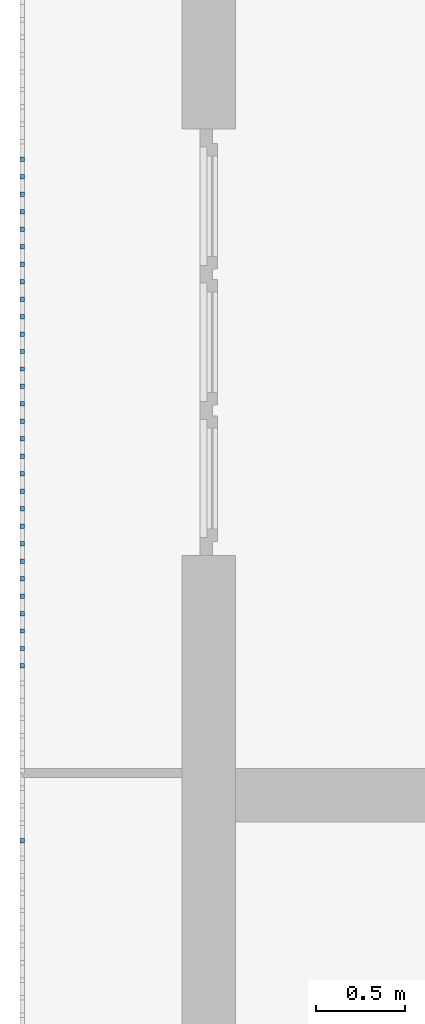
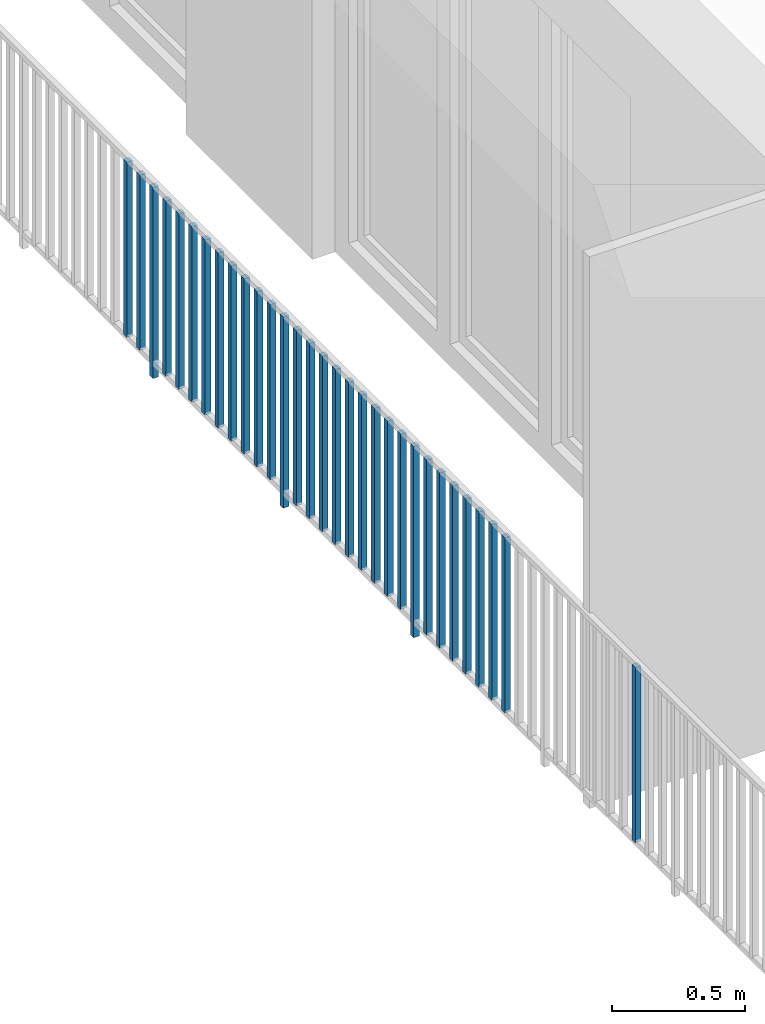
# One storey, part 38 of 54: 31 building element parts, 1 element without a shape of its own.
"""IFC4 building model written with IfcOpenShell, lengths in metres."""

from ifc_helpers import new_model, entity, si_unit, converted_unit, derived_unit, direction, frame, origin_with_axes, place, context, subcontext, project, spatial, polygons, material, type_object, element, aggregate, save


model = new_model("IFC4")

# Units and contexts
model_context = context("Model", 3, precision=1e-05, world=origin_with_axes(), true_north=direction((0.0, 1.0)))
body_context = subcontext(model_context, "Body", "Model", "MODEL_VIEW")
ifc_project = project(units=[si_unit("LENGTHUNIT", "METRE"), si_unit("AREAUNIT", "SQUARE_METRE"), si_unit("VOLUMEUNIT", "CUBIC_METRE"), converted_unit("PLANEANGLEUNIT", "DEGREE", entity("IfcPlaneAngleMeasure", 0.0174532925199), si_unit("PLANEANGLEUNIT", "RADIAN"), dimensions=[0, 0, 0, 0, 0, 0, 0]), converted_unit("TIMEUNIT", "Year", entity("IfcTimeMeasure", 31556926.0), si_unit("TIMEUNIT", "SECOND"), dimensions=[0, 0, 1, 0, 0, 0, 0]), si_unit("MASSUNIT", "GRAM", prefix="KILO"), si_unit("THERMODYNAMICTEMPERATUREUNIT", "DEGREE_CELSIUS"), si_unit("LUMINOUSINTENSITYUNIT", "LUMEN"), si_unit("ENERGYUNIT", "JOULE", prefix="MEGA"), derived_unit("THERMALCONDUCTANCEUNIT", [(si_unit("POWERUNIT", "WATT"), 1), (si_unit("LENGTHUNIT", "METRE"), -1), (si_unit("THERMODYNAMICTEMPERATUREUNIT", "KELVIN"), -1)]), derived_unit("SPECIFICHEATCAPACITYUNIT", [(si_unit("ENERGYUNIT", "JOULE"), 1), (si_unit("MASSUNIT", "GRAM", prefix="KILO"), -1), (si_unit("THERMODYNAMICTEMPERATUREUNIT", "KELVIN"), -1)]), derived_unit("MASSDENSITYUNIT", [(si_unit("MASSUNIT", "GRAM", prefix="KILO"), 1), (si_unit("VOLUMEUNIT", "CUBIC_METRE"), -1)])], contexts=[model_context])

# Site, building, storey, space
site_placement = place(None, origin_with_axes())
site = spatial("IfcSite", under=ifc_project, at=site_placement, CompositionType="ELEMENT")
building_placement = place(site_placement, origin_with_axes())
building = spatial("IfcBuilding", under=site, at=building_placement, CompositionType="ELEMENT")
storey_placement = place(building_placement, frame((0.0, 0.0, 6.29), z_axis=(0.0, 0.0, 1.0), x_axis=(1.0, 0.0, 0.0)))
storey = spatial("IfcBuildingStorey", under=building, at=storey_placement, Name="2. Geschoss", CompositionType="ELEMENT", Elevation=6.29)
space_placement = place(storey_placement, frame((10.2378006196, 9.82118769833, 0.0), z_axis=(0.0, 0.0, 1.0), x_axis=(-1.0, 0.0, 0.0)))
space = spatial("IfcSpace", under=storey, at=space_placement, CompositionType="ELEMENT", PredefinedType="EXTERNAL")

# Railing, building element parts
railing_type = type_object("IfcRailingType", PredefinedType="NOTDEFINED")
railing_placement = place(space_placement, frame((0.0, -7.06315681498e-08, 0.0), z_axis=(0.0, 0.0, 1.0), x_axis=(-1.0, 0.0, 0.0)))
railing = element("IfcRailing", 1, at=railing_placement, inside=space, type_object=railing_type, PredefinedType="NOTDEFINED")
ifc_material = material()
building_element_part_1_placement = place(railing_placement, origin_with_axes())
building_element_part_1 = element("IfcBuildingElementPart", 2, at=building_element_part_1_placement, material=ifc_material, PredefinedType="NOTDEFINED", context=body_context, shape_type="Tessellation", body=[
    polygons([(-22.8925, -4.7325, 0.07), (-22.8675, -4.7325, 0.07), (-22.8675, -4.7325, 0.8775), (-22.8925, -4.7325, 0.8775), (-22.8925, -4.7075, 0.07), (-22.8675, -4.7075, 0.07), (-22.8675, -4.7075, 0.8775), (-22.8925, -4.7075, 0.8775)], [[[1, 2, 3, 4]], [[1, 5, 6, 2]], [[2, 6, 7, 3]], [[4, 3, 7, 8]], [[5, 1, 4, 8]], [[6, 5, 8, 7]]], closed=True),
])
building_element_part_2_placement = place(railing_placement, origin_with_axes())
building_element_part_2 = element("IfcBuildingElementPart", 3, at=building_element_part_2_placement, material=ifc_material, PredefinedType="NOTDEFINED", context=body_context, shape_type="Tessellation", body=[
    polygons([(-22.8925, -4.83083333333, 0.07), (-22.8675, -4.83083333333, 0.07), (-22.8675, -4.83083333333, 0.8775), (-22.8925, -4.83083333333, 0.8775), (-22.8925, -4.80583333333, 0.07), (-22.8675, -4.80583333333, 0.07), (-22.8675, -4.80583333333, 0.8775), (-22.8925, -4.80583333333, 0.8775)], [[[1, 2, 3, 4]], [[1, 5, 6, 2]], [[2, 6, 7, 3]], [[4, 3, 7, 8]], [[5, 1, 4, 8]], [[6, 5, 8, 7]]], closed=True),
])
building_element_part_3_placement = place(railing_placement, origin_with_axes())
building_element_part_3 = element("IfcBuildingElementPart", 4, at=building_element_part_3_placement, material=ifc_material, PredefinedType="NOTDEFINED", context=body_context, shape_type="Tessellation", body=[
    polygons([(-22.8925, -4.92916666667, 0.0), (-22.8675, -4.92916666667, 0.0), (-22.8675, -4.92916666667, 0.88), (-22.8925, -4.92916666667, 0.88), (-22.8925, -4.90416666667, 0.0), (-22.8675, -4.90416666667, 0.0), (-22.8675, -4.90416666667, 0.88), (-22.8925, -4.90416666667, 0.88)], [[[1, 2, 3, 4]], [[1, 5, 6, 2]], [[2, 6, 7, 3]], [[4, 3, 7, 8]], [[5, 1, 4, 8]], [[6, 5, 8, 7]]], closed=True),
])
building_element_part_4_placement = place(railing_placement, origin_with_axes())
building_element_part_4 = element("IfcBuildingElementPart", 5, at=building_element_part_4_placement, material=ifc_material, PredefinedType="NOTDEFINED", context=body_context, shape_type="Tessellation", body=[
    polygons([(-22.8925, -5.0275, 0.07), (-22.8675, -5.0275, 0.07), (-22.8675, -5.0275, 0.8775), (-22.8925, -5.0275, 0.8775), (-22.8925, -5.0025, 0.07), (-22.8675, -5.0025, 0.07), (-22.8675, -5.0025, 0.8775), (-22.8925, -5.0025, 0.8775)], [[[1, 2, 3, 4]], [[1, 5, 6, 2]], [[2, 6, 7, 3]], [[4, 3, 7, 8]], [[5, 1, 4, 8]], [[6, 5, 8, 7]]], closed=True),
])
building_element_part_5_placement = place(railing_placement, origin_with_axes())
building_element_part_5 = element("IfcBuildingElementPart", 6, at=building_element_part_5_placement, material=ifc_material, PredefinedType="NOTDEFINED", context=body_context, shape_type="Tessellation", body=[
    polygons([(-22.8925, -5.12583333333, 0.07), (-22.8675, -5.12583333333, 0.07), (-22.8675, -5.12583333333, 0.8775), (-22.8925, -5.12583333333, 0.8775), (-22.8925, -5.10083333333, 0.07), (-22.8675, -5.10083333333, 0.07), (-22.8675, -5.10083333333, 0.8775), (-22.8925, -5.10083333333, 0.8775)], [[[1, 2, 3, 4]], [[1, 5, 6, 2]], [[2, 6, 7, 3]], [[4, 3, 7, 8]], [[5, 1, 4, 8]], [[6, 5, 8, 7]]], closed=True),
])
building_element_part_6_placement = place(railing_placement, origin_with_axes())
building_element_part_6 = element("IfcBuildingElementPart", 7, at=building_element_part_6_placement, material=ifc_material, PredefinedType="NOTDEFINED", context=body_context, shape_type="Tessellation", body=[
    polygons([(-22.8925, -5.22416666667, 0.07), (-22.8675, -5.22416666667, 0.07), (-22.8675, -5.22416666667, 0.8775), (-22.8925, -5.22416666667, 0.8775), (-22.8925, -5.19916666667, 0.07), (-22.8675, -5.19916666667, 0.07), (-22.8675, -5.19916666667, 0.8775), (-22.8925, -5.19916666667, 0.8775)], [[[1, 2, 3, 4]], [[1, 5, 6, 2]], [[2, 6, 7, 3]], [[4, 3, 7, 8]], [[5, 1, 4, 8]], [[6, 5, 8, 7]]], closed=True),
])
building_element_part_7_placement = place(railing_placement, origin_with_axes())
building_element_part_7 = element("IfcBuildingElementPart", 8, at=building_element_part_7_placement, material=ifc_material, PredefinedType="NOTDEFINED", context=body_context, shape_type="Tessellation", body=[
    polygons([(-22.8925, -5.3225, 0.07), (-22.8675, -5.3225, 0.07), (-22.8675, -5.3225, 0.8775), (-22.8925, -5.3225, 0.8775), (-22.8925, -5.2975, 0.07), (-22.8675, -5.2975, 0.07), (-22.8675, -5.2975, 0.8775), (-22.8925, -5.2975, 0.8775)], [[[1, 2, 3, 4]], [[1, 5, 6, 2]], [[2, 6, 7, 3]], [[4, 3, 7, 8]], [[5, 1, 4, 8]], [[6, 5, 8, 7]]], closed=True),
])
building_element_part_8_placement = place(railing_placement, origin_with_axes())
building_element_part_8 = element("IfcBuildingElementPart", 9, at=building_element_part_8_placement, material=ifc_material, PredefinedType="NOTDEFINED", context=body_context, shape_type="Tessellation", body=[
    polygons([(-22.8925, -5.42083333333, 0.07), (-22.8675, -5.42083333333, 0.07), (-22.8675, -5.42083333333, 0.8775), (-22.8925, -5.42083333333, 0.8775), (-22.8925, -5.39583333333, 0.07), (-22.8675, -5.39583333333, 0.07), (-22.8675, -5.39583333333, 0.8775), (-22.8925, -5.39583333333, 0.8775)], [[[1, 2, 3, 4]], [[1, 5, 6, 2]], [[2, 6, 7, 3]], [[4, 3, 7, 8]], [[5, 1, 4, 8]], [[6, 5, 8, 7]]], closed=True),
])
building_element_part_9_placement = place(railing_placement, origin_with_axes())
building_element_part_9 = element("IfcBuildingElementPart", 10, at=building_element_part_9_placement, material=ifc_material, PredefinedType="NOTDEFINED", context=body_context, shape_type="Tessellation", body=[
    polygons([(-22.8925, -5.51916666667, 0.07), (-22.8675, -5.51916666667, 0.07), (-22.8675, -5.51916666667, 0.8775), (-22.8925, -5.51916666667, 0.8775), (-22.8925, -5.49416666667, 0.07), (-22.8675, -5.49416666667, 0.07), (-22.8675, -5.49416666667, 0.8775), (-22.8925, -5.49416666667, 0.8775)], [[[1, 2, 3, 4]], [[1, 5, 6, 2]], [[2, 6, 7, 3]], [[4, 3, 7, 8]], [[5, 1, 4, 8]], [[6, 5, 8, 7]]], closed=True),
])
building_element_part_10_placement = place(railing_placement, origin_with_axes())
building_element_part_10 = element("IfcBuildingElementPart", 11, at=building_element_part_10_placement, material=ifc_material, PredefinedType="NOTDEFINED", context=body_context, shape_type="Tessellation", body=[
    polygons([(-22.8925, -5.6175, 0.07), (-22.8675, -5.6175, 0.07), (-22.8675, -5.6175, 0.8775), (-22.8925, -5.6175, 0.8775), (-22.8925, -5.5925, 0.07), (-22.8675, -5.5925, 0.07), (-22.8675, -5.5925, 0.8775), (-22.8925, -5.5925, 0.8775)], [[[1, 2, 3, 4]], [[1, 5, 6, 2]], [[2, 6, 7, 3]], [[4, 3, 7, 8]], [[5, 1, 4, 8]], [[6, 5, 8, 7]]], closed=True),
])
building_element_part_11_placement = place(railing_placement, origin_with_axes())
building_element_part_11 = element("IfcBuildingElementPart", 12, at=building_element_part_11_placement, material=ifc_material, PredefinedType="NOTDEFINED", context=body_context, shape_type="Tessellation", body=[
    polygons([(-22.8925, -5.71583333333, 0.07), (-22.8675, -5.71583333333, 0.07), (-22.8675, -5.71583333333, 0.8775), (-22.8925, -5.71583333333, 0.8775), (-22.8925, -5.69083333333, 0.07), (-22.8675, -5.69083333333, 0.07), (-22.8675, -5.69083333333, 0.8775), (-22.8925, -5.69083333333, 0.8775)], [[[1, 2, 3, 4]], [[1, 5, 6, 2]], [[2, 6, 7, 3]], [[4, 3, 7, 8]], [[5, 1, 4, 8]], [[6, 5, 8, 7]]], closed=True),
])
building_element_part_12_placement = place(railing_placement, origin_with_axes())
building_element_part_12 = element("IfcBuildingElementPart", 13, at=building_element_part_12_placement, material=ifc_material, PredefinedType="NOTDEFINED", context=body_context, shape_type="Tessellation", body=[
    polygons([(-22.8925, -5.81416666667, 0.07), (-22.8675, -5.81416666667, 0.07), (-22.8675, -5.81416666667, 0.8775), (-22.8925, -5.81416666667, 0.8775), (-22.8925, -5.78916666667, 0.07), (-22.8675, -5.78916666667, 0.07), (-22.8675, -5.78916666667, 0.8775), (-22.8925, -5.78916666667, 0.8775)], [[[1, 2, 3, 4]], [[1, 5, 6, 2]], [[2, 6, 7, 3]], [[4, 3, 7, 8]], [[5, 1, 4, 8]], [[6, 5, 8, 7]]], closed=True),
])
building_element_part_13_placement = place(railing_placement, origin_with_axes())
building_element_part_13 = element("IfcBuildingElementPart", 14, at=building_element_part_13_placement, material=ifc_material, PredefinedType="NOTDEFINED", context=body_context, shape_type="Tessellation", body=[
    polygons([(-22.8925, -5.9125, 0.0), (-22.8675, -5.9125, 0.0), (-22.8675, -5.9125, 0.88), (-22.8925, -5.9125, 0.88), (-22.8925, -5.8875, 0.0), (-22.8675, -5.8875, 0.0), (-22.8675, -5.8875, 0.88), (-22.8925, -5.8875, 0.88)], [[[1, 2, 3, 4]], [[1, 5, 6, 2]], [[2, 6, 7, 3]], [[4, 3, 7, 8]], [[5, 1, 4, 8]], [[6, 5, 8, 7]]], closed=True),
])
building_element_part_14_placement = place(railing_placement, origin_with_axes())
building_element_part_14 = element("IfcBuildingElementPart", 15, at=building_element_part_14_placement, material=ifc_material, PredefinedType="NOTDEFINED", context=body_context, shape_type="Tessellation", body=[
    polygons([(-22.8925, -6.01083333333, 0.07), (-22.8675, -6.01083333333, 0.07), (-22.8675, -6.01083333333, 0.8775), (-22.8925, -6.01083333333, 0.8775), (-22.8925, -5.98583333333, 0.07), (-22.8675, -5.98583333333, 0.07), (-22.8675, -5.98583333333, 0.8775), (-22.8925, -5.98583333333, 0.8775)], [[[1, 2, 3, 4]], [[1, 5, 6, 2]], [[2, 6, 7, 3]], [[4, 3, 7, 8]], [[5, 1, 4, 8]], [[6, 5, 8, 7]]], closed=True),
])
building_element_part_15_placement = place(railing_placement, origin_with_axes())
building_element_part_15 = element("IfcBuildingElementPart", 16, at=building_element_part_15_placement, material=ifc_material, PredefinedType="NOTDEFINED", context=body_context, shape_type="Tessellation", body=[
    polygons([(-22.8925, -6.10916666667, 0.07), (-22.8675, -6.10916666667, 0.07), (-22.8675, -6.10916666667, 0.8775), (-22.8925, -6.10916666667, 0.8775), (-22.8925, -6.08416666667, 0.07), (-22.8675, -6.08416666667, 0.07), (-22.8675, -6.08416666667, 0.8775), (-22.8925, -6.08416666667, 0.8775)], [[[1, 2, 3, 4]], [[1, 5, 6, 2]], [[2, 6, 7, 3]], [[4, 3, 7, 8]], [[5, 1, 4, 8]], [[6, 5, 8, 7]]], closed=True),
])
building_element_part_16_placement = place(railing_placement, origin_with_axes())
building_element_part_16 = element("IfcBuildingElementPart", 17, at=building_element_part_16_placement, material=ifc_material, PredefinedType="NOTDEFINED", context=body_context, shape_type="Tessellation", body=[
    polygons([(-22.8925, -6.2075, 0.07), (-22.8675, -6.2075, 0.07), (-22.8675, -6.2075, 0.8775), (-22.8925, -6.2075, 0.8775), (-22.8925, -6.1825, 0.07), (-22.8675, -6.1825, 0.07), (-22.8675, -6.1825, 0.8775), (-22.8925, -6.1825, 0.8775)], [[[1, 2, 3, 4]], [[1, 5, 6, 2]], [[2, 6, 7, 3]], [[4, 3, 7, 8]], [[5, 1, 4, 8]], [[6, 5, 8, 7]]], closed=True),
])
building_element_part_17_placement = place(railing_placement, origin_with_axes())
building_element_part_17 = element("IfcBuildingElementPart", 18, at=building_element_part_17_placement, material=ifc_material, PredefinedType="NOTDEFINED", context=body_context, shape_type="Tessellation", body=[
    polygons([(-22.8925, -6.30583333333, 0.07), (-22.8675, -6.30583333333, 0.07), (-22.8675, -6.30583333333, 0.8775), (-22.8925, -6.30583333333, 0.8775), (-22.8925, -6.28083333333, 0.07), (-22.8675, -6.28083333333, 0.07), (-22.8675, -6.28083333333, 0.8775), (-22.8925, -6.28083333333, 0.8775)], [[[1, 2, 3, 4]], [[1, 5, 6, 2]], [[2, 6, 7, 3]], [[4, 3, 7, 8]], [[5, 1, 4, 8]], [[6, 5, 8, 7]]], closed=True),
])
building_element_part_18_placement = place(railing_placement, origin_with_axes())
building_element_part_18 = element("IfcBuildingElementPart", 19, at=building_element_part_18_placement, material=ifc_material, PredefinedType="NOTDEFINED", context=body_context, shape_type="Tessellation", body=[
    polygons([(-22.8925, -6.40416666667, 0.07), (-22.8675, -6.40416666667, 0.07), (-22.8675, -6.40416666667, 0.8775), (-22.8925, -6.40416666667, 0.8775), (-22.8925, -6.37916666667, 0.07), (-22.8675, -6.37916666667, 0.07), (-22.8675, -6.37916666667, 0.8775), (-22.8925, -6.37916666667, 0.8775)], [[[1, 2, 3, 4]], [[1, 5, 6, 2]], [[2, 6, 7, 3]], [[4, 3, 7, 8]], [[5, 1, 4, 8]], [[6, 5, 8, 7]]], closed=True),
])
building_element_part_19_placement = place(railing_placement, origin_with_axes())
building_element_part_19 = element("IfcBuildingElementPart", 20, at=building_element_part_19_placement, material=ifc_material, PredefinedType="NOTDEFINED", context=body_context, shape_type="Tessellation", body=[
    polygons([(-22.8925, -6.5025, 0.07), (-22.8675, -6.5025, 0.07), (-22.8675, -6.5025, 0.8775), (-22.8925, -6.5025, 0.8775), (-22.8925, -6.4775, 0.07), (-22.8675, -6.4775, 0.07), (-22.8675, -6.4775, 0.8775), (-22.8925, -6.4775, 0.8775)], [[[1, 2, 3, 4]], [[1, 5, 6, 2]], [[2, 6, 7, 3]], [[4, 3, 7, 8]], [[5, 1, 4, 8]], [[6, 5, 8, 7]]], closed=True),
])
building_element_part_20_placement = place(railing_placement, origin_with_axes())
building_element_part_20 = element("IfcBuildingElementPart", 21, at=building_element_part_20_placement, material=ifc_material, PredefinedType="NOTDEFINED", context=body_context, shape_type="Tessellation", body=[
    polygons([(-22.8925, -6.60083333333, 0.07), (-22.8675, -6.60083333333, 0.07), (-22.8675, -6.60083333333, 0.8775), (-22.8925, -6.60083333333, 0.8775), (-22.8925, -6.57583333333, 0.07), (-22.8675, -6.57583333333, 0.07), (-22.8675, -6.57583333333, 0.8775), (-22.8925, -6.57583333333, 0.8775)], [[[1, 2, 3, 4]], [[1, 5, 6, 2]], [[2, 6, 7, 3]], [[4, 3, 7, 8]], [[5, 1, 4, 8]], [[6, 5, 8, 7]]], closed=True),
])
building_element_part_21_placement = place(railing_placement, origin_with_axes())
building_element_part_21 = element("IfcBuildingElementPart", 22, at=building_element_part_21_placement, material=ifc_material, PredefinedType="NOTDEFINED", context=body_context, shape_type="Tessellation", body=[
    polygons([(-22.8925, -6.69916666667, 0.07), (-22.8675, -6.69916666667, 0.07), (-22.8675, -6.69916666667, 0.8775), (-22.8925, -6.69916666667, 0.8775), (-22.8925, -6.67416666667, 0.07), (-22.8675, -6.67416666667, 0.07), (-22.8675, -6.67416666667, 0.8775), (-22.8925, -6.67416666667, 0.8775)], [[[1, 2, 3, 4]], [[1, 5, 6, 2]], [[2, 6, 7, 3]], [[4, 3, 7, 8]], [[5, 1, 4, 8]], [[6, 5, 8, 7]]], closed=True),
])
building_element_part_22_placement = place(railing_placement, origin_with_axes())
building_element_part_22 = element("IfcBuildingElementPart", 23, at=building_element_part_22_placement, material=ifc_material, PredefinedType="NOTDEFINED", context=body_context, shape_type="Tessellation", body=[
    polygons([(-22.8925, -6.7975, 0.07), (-22.8675, -6.7975, 0.07), (-22.8675, -6.7975, 0.8775), (-22.8925, -6.7975, 0.8775), (-22.8925, -6.7725, 0.07), (-22.8675, -6.7725, 0.07), (-22.8675, -6.7725, 0.8775), (-22.8925, -6.7725, 0.8775)], [[[1, 2, 3, 4]], [[1, 5, 6, 2]], [[2, 6, 7, 3]], [[4, 3, 7, 8]], [[5, 1, 4, 8]], [[6, 5, 8, 7]]], closed=True),
])
building_element_part_23_placement = place(railing_placement, origin_with_axes())
building_element_part_23 = element("IfcBuildingElementPart", 24, at=building_element_part_23_placement, material=ifc_material, PredefinedType="NOTDEFINED", context=body_context, shape_type="Tessellation", body=[
    polygons([(-22.8925, -6.89583333333, 0.0), (-22.8675, -6.89583333333, 0.0), (-22.8675, -6.89583333333, 0.88), (-22.8925, -6.89583333333, 0.88), (-22.8925, -6.87083333333, 0.0), (-22.8675, -6.87083333333, 0.0), (-22.8675, -6.87083333333, 0.88), (-22.8925, -6.87083333333, 0.88)], [[[1, 2, 3, 4]], [[1, 5, 6, 2]], [[2, 6, 7, 3]], [[4, 3, 7, 8]], [[5, 1, 4, 8]], [[6, 5, 8, 7]]], closed=True),
])
building_element_part_24_placement = place(railing_placement, origin_with_axes())
building_element_part_24 = element("IfcBuildingElementPart", 25, at=building_element_part_24_placement, material=ifc_material, PredefinedType="NOTDEFINED", context=body_context, shape_type="Tessellation", body=[
    polygons([(-22.8925, -6.99416666667, 0.07), (-22.8675, -6.99416666667, 0.07), (-22.8675, -6.99416666667, 0.8775), (-22.8925, -6.99416666667, 0.8775), (-22.8925, -6.96916666667, 0.07), (-22.8675, -6.96916666667, 0.07), (-22.8675, -6.96916666667, 0.8775), (-22.8925, -6.96916666667, 0.8775)], [[[1, 2, 3, 4]], [[1, 5, 6, 2]], [[2, 6, 7, 3]], [[4, 3, 7, 8]], [[5, 1, 4, 8]], [[6, 5, 8, 7]]], closed=True),
])
building_element_part_25_placement = place(railing_placement, origin_with_axes())
building_element_part_25 = element("IfcBuildingElementPart", 26, at=building_element_part_25_placement, material=ifc_material, PredefinedType="NOTDEFINED", context=body_context, shape_type="Tessellation", body=[
    polygons([(-22.8925, -7.0925, 0.07), (-22.8675, -7.0925, 0.07), (-22.8675, -7.0925, 0.8775), (-22.8925, -7.0925, 0.8775), (-22.8925, -7.0675, 0.07), (-22.8675, -7.0675, 0.07), (-22.8675, -7.0675, 0.8775), (-22.8925, -7.0675, 0.8775)], [[[1, 2, 3, 4]], [[1, 5, 6, 2]], [[2, 6, 7, 3]], [[4, 3, 7, 8]], [[5, 1, 4, 8]], [[6, 5, 8, 7]]], closed=True),
])
building_element_part_26_placement = place(railing_placement, origin_with_axes())
building_element_part_26 = element("IfcBuildingElementPart", 27, at=building_element_part_26_placement, material=ifc_material, PredefinedType="NOTDEFINED", context=body_context, shape_type="Tessellation", body=[
    polygons([(-22.8925, -7.19083333333, 0.07), (-22.8675, -7.19083333333, 0.07), (-22.8675, -7.19083333333, 0.8775), (-22.8925, -7.19083333333, 0.8775), (-22.8925, -7.16583333333, 0.07), (-22.8675, -7.16583333333, 0.07), (-22.8675, -7.16583333333, 0.8775), (-22.8925, -7.16583333333, 0.8775)], [[[1, 2, 3, 4]], [[1, 5, 6, 2]], [[2, 6, 7, 3]], [[4, 3, 7, 8]], [[5, 1, 4, 8]], [[6, 5, 8, 7]]], closed=True),
])
building_element_part_27_placement = place(railing_placement, origin_with_axes())
building_element_part_27 = element("IfcBuildingElementPart", 28, at=building_element_part_27_placement, material=ifc_material, PredefinedType="NOTDEFINED", context=body_context, shape_type="Tessellation", body=[
    polygons([(-22.8925, -7.28916666667, 0.07), (-22.8675, -7.28916666667, 0.07), (-22.8675, -7.28916666667, 0.8775), (-22.8925, -7.28916666667, 0.8775), (-22.8925, -7.26416666667, 0.07), (-22.8675, -7.26416666667, 0.07), (-22.8675, -7.26416666667, 0.8775), (-22.8925, -7.26416666667, 0.8775)], [[[1, 2, 3, 4]], [[1, 5, 6, 2]], [[2, 6, 7, 3]], [[4, 3, 7, 8]], [[5, 1, 4, 8]], [[6, 5, 8, 7]]], closed=True),
])
building_element_part_28_placement = place(railing_placement, origin_with_axes())
building_element_part_28 = element("IfcBuildingElementPart", 29, at=building_element_part_28_placement, material=ifc_material, PredefinedType="NOTDEFINED", context=body_context, shape_type="Tessellation", body=[
    polygons([(-22.8925, -7.3875, 0.07), (-22.8675, -7.3875, 0.07), (-22.8675, -7.3875, 0.8775), (-22.8925, -7.3875, 0.8775), (-22.8925, -7.3625, 0.07), (-22.8675, -7.3625, 0.07), (-22.8675, -7.3625, 0.8775), (-22.8925, -7.3625, 0.8775)], [[[1, 2, 3, 4]], [[1, 5, 6, 2]], [[2, 6, 7, 3]], [[4, 3, 7, 8]], [[5, 1, 4, 8]], [[6, 5, 8, 7]]], closed=True),
])
building_element_part_29_placement = place(railing_placement, origin_with_axes())
building_element_part_29 = element("IfcBuildingElementPart", 30, at=building_element_part_29_placement, material=ifc_material, PredefinedType="NOTDEFINED", context=body_context, shape_type="Tessellation", body=[
    polygons([(-22.8925, -7.48583333333, 0.07), (-22.8675, -7.48583333333, 0.07), (-22.8675, -7.48583333333, 0.8775), (-22.8925, -7.48583333333, 0.8775), (-22.8925, -7.46083333333, 0.07), (-22.8675, -7.46083333333, 0.07), (-22.8675, -7.46083333333, 0.8775), (-22.8925, -7.46083333333, 0.8775)], [[[1, 2, 3, 4]], [[1, 5, 6, 2]], [[2, 6, 7, 3]], [[4, 3, 7, 8]], [[5, 1, 4, 8]], [[6, 5, 8, 7]]], closed=True),
])
building_element_part_30_placement = place(railing_placement, origin_with_axes())
building_element_part_30 = element("IfcBuildingElementPart", 31, at=building_element_part_30_placement, material=ifc_material, PredefinedType="NOTDEFINED", context=body_context, shape_type="Tessellation", body=[
    polygons([(-22.8925, -7.58416666667, 0.07), (-22.8675, -7.58416666667, 0.07), (-22.8675, -7.58416666667, 0.8775), (-22.8925, -7.58416666667, 0.8775), (-22.8925, -7.55916666667, 0.07), (-22.8675, -7.55916666667, 0.07), (-22.8675, -7.55916666667, 0.8775), (-22.8925, -7.55916666667, 0.8775)], [[[1, 2, 3, 4]], [[1, 5, 6, 2]], [[2, 6, 7, 3]], [[4, 3, 7, 8]], [[5, 1, 4, 8]], [[6, 5, 8, 7]]], closed=True),
])
building_element_part_31_placement = place(railing_placement, origin_with_axes())
building_element_part_31 = element("IfcBuildingElementPart", 32, at=building_element_part_31_placement, material=ifc_material, PredefinedType="NOTDEFINED", context=body_context, shape_type="Tessellation", body=[
    polygons([(-22.8925, -8.5675, 0.07), (-22.8675, -8.5675, 0.07), (-22.8675, -8.5675, 0.8775), (-22.8925, -8.5675, 0.8775), (-22.8925, -8.5425, 0.07), (-22.8675, -8.5425, 0.07), (-22.8675, -8.5425, 0.8775), (-22.8925, -8.5425, 0.8775)], [[[1, 2, 3, 4]], [[1, 5, 6, 2]], [[2, 6, 7, 3]], [[4, 3, 7, 8]], [[5, 1, 4, 8]], [[6, 5, 8, 7]]], closed=True),
])
aggregate(railing, [building_element_part_1, building_element_part_2, building_element_part_3, building_element_part_4, building_element_part_5, building_element_part_6, building_element_part_7, building_element_part_8, building_element_part_9, building_element_part_10, building_element_part_11, building_element_part_12, building_element_part_13, building_element_part_14, building_element_part_15, building_element_part_16, building_element_part_17, building_element_part_18, building_element_part_19, building_element_part_20, building_element_part_21, building_element_part_22, building_element_part_23, building_element_part_24, building_element_part_25, building_element_part_26, building_element_part_27, building_element_part_28, building_element_part_29, building_element_part_30, building_element_part_31])

save(model, "model.ifc")
